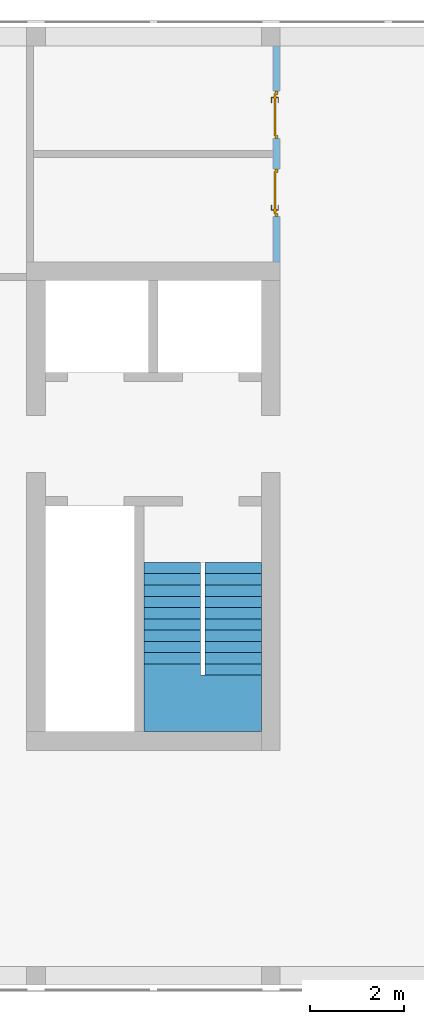
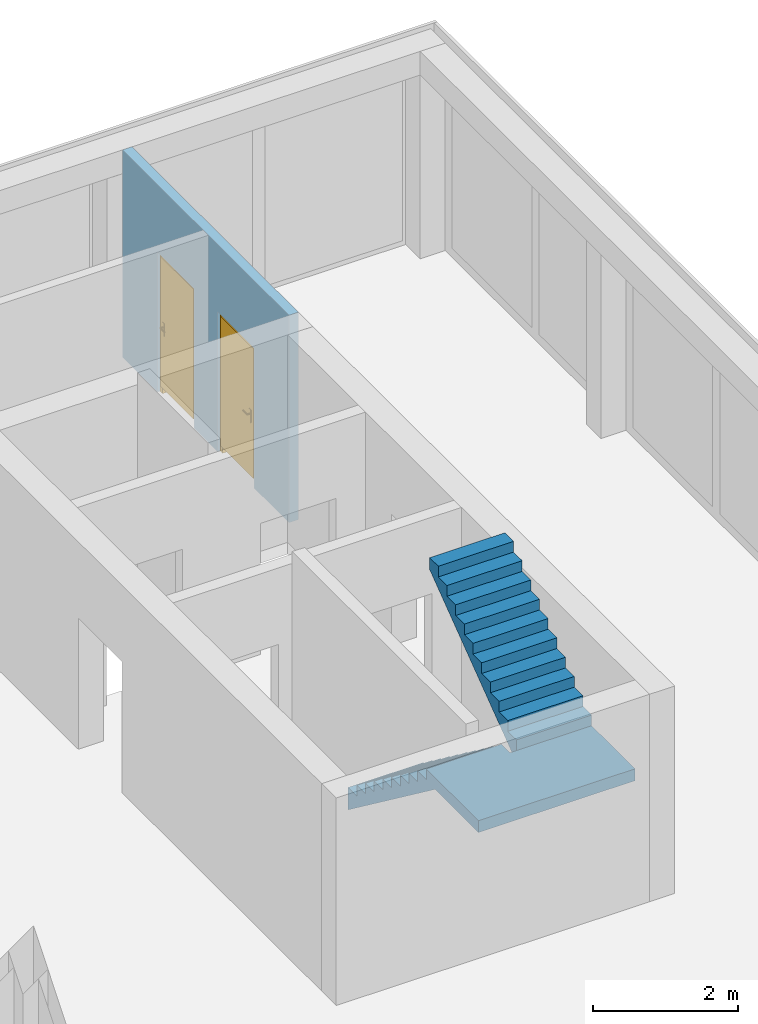
# One storey, part 4 of 6: 2 doors, 1 stair, 2 openings, plus 1 element that does not belong to this part.
"""IFC2X3 building model written with IfcOpenShell, lengths in metres."""

from ifc_helpers import new_model, entity, si_unit, converted_unit, frame, frame_2d, origin, origin_with_axes, place, context, subcontext, project, spatial, polyline, rectangle, outline, extrude, faceted_brep, source, transform, mapped, material, layer, layer_set, layer_usage, type_object, element, fill, save


model = new_model("IFC2X3")

# Units and contexts
model_context = context("Model", 3, precision=1e-05, world=origin())
body_context = subcontext(model_context, "Body", "Model", "MODEL_VIEW")
ifc_project = project(units=[si_unit("LENGTHUNIT", "METRE"), si_unit("AREAUNIT", "SQUARE_METRE"), si_unit("VOLUMEUNIT", "CUBIC_METRE"), si_unit("MASSUNIT", "GRAM", prefix="KILO"), converted_unit("PLANEANGLEUNIT", "DEGREE", entity("IfcPlaneAngleMeasure", 0.0174532925199433), si_unit("PLANEANGLEUNIT", "RADIAN"), dimensions=[0, 0, 0, 0, 0, 0, 0])], contexts=[model_context])

# Site, building, storey
site_placement = place(None, origin())
site = spatial("IfcSite", under=ifc_project, at=site_placement, CompositionType="ELEMENT")
building_placement = place(site_placement, origin())
building = spatial("IfcBuilding", under=site, at=building_placement, CompositionType="ELEMENT")
storey_placement = place(building_placement, frame((0.0, 0.0, 8.6)))
storey = spatial("IfcBuildingStorey", under=building, at=storey_placement, Name="2. Obergeschoss", CompositionType="ELEMENT", Elevation=8.6)

# Wall, openings, doors
ifc_material_1 = material()
ifc_layer = layer(ifc_material_1, 0.15)
ifc_layer_set = layer_set([ifc_layer])
ifc_layer_usage = layer_usage(ifc_layer_set, "AXIS2", "POSITIVE", -0.15)
wall_placement = place(storey_placement, frame((25.25, 20.0, 0.0), z_axis=(0.0, 0.0, 1.0), x_axis=(0.0, -1.0, 0.0)))
wall = element("IfcWallStandardCase", 1, at=wall_placement, inside=storey, material=ifc_layer_usage, context=body_context, shape_type="SweptSolid", body=[
    extrude(rectangle(XDim=4.6, YDim=0.15, at=frame_2d((2.3, 0.075), x_axis=(1.0, 0.0))), origin_with_axes(), (0.0, 0.0, 1.0), 3.5),
])
opening_1_placement = place(wall_placement, frame((3.635, 0.15, 0.0), z_axis=(0.0, -1.0, 0.0), x_axis=(0.0, 0.0, 1.0)))
opening_1 = element("IfcOpeningElement", 2, at=opening_1_placement, cuts=wall, ObjectType="Opening", context=body_context, shape_type="SweptSolid", body=[
    extrude(outline(polyline([(0.0, 1.01), (2.36, 1.01), (2.36, 0.0), (0.0, 0.0), (0.0, 1.01)])), origin_with_axes(), (0.0, 0.0, 1.0), 0.15),
])
opening_2_placement = place(wall_placement, frame((1.975, 0.15, 0.0), z_axis=(0.0, -1.0, 0.0), x_axis=(0.0, 0.0, 1.0)))
opening_2 = element("IfcOpeningElement", 3, at=opening_2_placement, cuts=wall, ObjectType="Opening", context=body_context, shape_type="SweptSolid", body=[
    extrude(outline(polyline([(0.0, 1.01), (2.36, 1.01), (2.36, 0.0), (0.0, 0.0), (0.0, 1.01)])), origin_with_axes(), (0.0, 0.0, 1.0), 0.15),
])
ifc_material_2 = material()
door_style_1 = type_object("IfcDoorStyle", ConstructionType="NOTDEFINED", OperationType="SINGLE_SWING_RIGHT", ParameterTakesPrecedence=False, Sizeable=False)
shared_shape_1 = source(origin_with_axes(), body_context, "Body", "Brep", [
    faceted_brep([(0.0, 0.07, 2.36), (0.0, 0.07, 0.0), (0.07, 0.07, 0.0), (0.07, 0.07, 2.36), (0.0, 0.0, 0.0), (0.0, 0.0, 2.36), (0.07, 0.0, 2.36), (0.07, 0.0, 0.0)], [[[0, 1, 2, 3]], [[4, 5, 6, 7]], [[1, 0, 5, 4]], [[2, 1, 4, 7]], [[3, 2, 7, 6]], [[0, 3, 6, 5]]], orient=[[False], [False], [False], [False], [False], [False]]),
    faceted_brep([(0.94, 0.07, 2.36), (0.94, 0.07, 0.0), (1.01, 0.07, 0.0), (1.01, 0.07, 2.36), (0.94, 0.0, 0.0), (0.94, 0.0, 2.36), (1.01, 0.0, 2.36), (1.01, 0.0, 0.0)], [[[0, 1, 2, 3]], [[4, 5, 6, 7]], [[1, 0, 5, 4]], [[2, 1, 4, 7]], [[3, 2, 7, 6]], [[0, 3, 6, 5]]], orient=[[False], [False], [False], [False], [False], [False]]),
    faceted_brep([(0.07, 0.07, 2.36), (0.07, 0.07, 2.29), (0.94, 0.07, 2.29), (0.94, 0.07, 2.36), (0.07, 0.0, 2.29), (0.07, 0.0, 2.36), (0.94, 0.0, 2.36), (0.94, 0.0, 2.29)], [[[0, 1, 2, 3]], [[4, 5, 6, 7]], [[1, 0, 5, 4]], [[2, 1, 4, 7]], [[3, 2, 7, 6]], [[0, 3, 6, 5]]], orient=[[False], [False], [False], [False], [False], [False]]),
    faceted_brep([(0.05, 0.09, 2.31), (0.05, 0.09, 0.121), (0.96, 0.09, 0.121), (0.96, 0.09, 2.31), (0.05, 0.05, 0.121), (0.05, 0.05, 2.31), (0.96, 0.05, 2.31), (0.96, 0.05, 0.121)], [[[0, 1, 2, 3]], [[4, 5, 6, 7]], [[1, 0, 5, 4]], [[2, 1, 4, 7]], [[3, 2, 7, 6]], [[0, 3, 6, 5]]], orient=[[False], [False], [False], [False], [False], [False]]),
    faceted_brep([(0.11, 0.05, 1.246), (0.11, 0.05, 1.031), (0.16, 0.05, 1.031), (0.16, 0.05, 1.246), (0.11, 0.04, 1.031), (0.11, 0.04, 1.246), (0.16, 0.04, 1.246), (0.16, 0.04, 1.031)], [[[0, 1, 2, 3]], [[4, 5, 6, 7]], [[1, 0, 5, 4]], [[2, 1, 4, 7]], [[3, 2, 7, 6]], [[0, 3, 6, 5]]], orient=[[False], [False], [False], [False], [False], [False]]),
    faceted_brep([(0.135, 0.04, 1.181), (0.13, 0.04, 1.17966025403784), (0.126339745962156, 0.04, 1.176), (0.125, 0.04, 1.171), (0.126339745962156, 0.04, 1.166), (0.13, 0.04, 1.16233974596216), (0.135, 0.04, 1.161), (0.14, 0.04, 1.16233974596216), (0.143660254037844, 0.04, 1.166), (0.145, 0.04, 1.171), (0.143660254037844, 0.04, 1.176), (0.14, 0.04, 1.17966025403784), (0.135, 0.0, 1.181), (0.13, -0.005, 1.17966025403784), (0.126339745962156, -0.00866025403784442, 1.176), (0.125, -0.01, 1.171), (0.126339745962156, -0.00866025403784442, 1.166), (0.13, -0.005, 1.16233974596216), (0.135, 0.0, 1.161), (0.14, 0.005, 1.16233974596216), (0.143660254037844, 0.00866025403784442, 1.166), (0.145, 0.01, 1.171), (0.143660254037844, 0.00866025403784442, 1.176), (0.14, 0.005, 1.17966025403784), (0.25, 0.0, 1.181), (0.25, 0.005, 1.17966025403784), (0.25, 0.00866025403784442, 1.176), (0.25, 0.01, 1.171), (0.25, 0.00866025403784442, 1.166), (0.25, 0.005, 1.16233974596216), (0.25, 0.0, 1.161), (0.25, -0.005, 1.16233974596216), (0.25, -0.00866025403784442, 1.166), (0.25, -0.01, 1.171), (0.25, -0.00866025403784442, 1.176), (0.25, -0.005, 1.17966025403784)], [[[0, 1, 2, 3, 4, 5, 6, 7, 8, 9, 10, 11]], [[0, 12, 13, 1]], [[1, 13, 14, 2]], [[2, 14, 15, 3]], [[3, 15, 16, 4]], [[4, 16, 17, 5]], [[5, 17, 18, 6]], [[6, 18, 19, 7]], [[7, 19, 20, 8]], [[8, 20, 21, 9]], [[9, 21, 22, 10]], [[10, 22, 23, 11]], [[11, 23, 12, 0]], [[24, 25, 26, 27, 28, 29, 30, 31, 32, 33, 34, 35]], [[12, 24, 35, 13]], [[13, 35, 34, 14]], [[14, 34, 33, 15]], [[15, 33, 32, 16]], [[16, 32, 31, 17]], [[17, 31, 30, 18]], [[18, 30, 29, 19]], [[19, 29, 28, 20]], [[20, 28, 27, 21]], [[21, 27, 26, 22]], [[22, 26, 25, 23]], [[23, 25, 24, 12]]], orient=[[False], [False], [False], [False], [False], [False], [False], [False], [False], [False], [False], [False], [False], [False], [False], [False], [False], [False], [False], [False], [False], [False], [False], [False], [False], [False]]),
    faceted_brep([(0.11, 0.09, 1.246), (0.16, 0.09, 1.246), (0.16, 0.09, 1.031), (0.11, 0.09, 1.031), (0.11, 0.1, 1.031), (0.16, 0.1, 1.031), (0.16, 0.1, 1.246), (0.11, 0.1, 1.246)], [[[0, 1, 2, 3]], [[4, 5, 6, 7]], [[3, 4, 7, 0]], [[2, 5, 4, 3]], [[1, 6, 5, 2]], [[0, 7, 6, 1]]], orient=[[False], [False], [False], [False], [False], [False]]),
    faceted_brep([(0.135, 0.1, 1.181), (0.14, 0.1, 1.17966025403784), (0.143660254037844, 0.1, 1.176), (0.145, 0.1, 1.171), (0.143660254037844, 0.1, 1.166), (0.14, 0.1, 1.16233974596216), (0.135, 0.1, 1.161), (0.13, 0.1, 1.16233974596216), (0.126339745962156, 0.1, 1.166), (0.125, 0.1, 1.171), (0.126339745962156, 0.1, 1.176), (0.13, 0.1, 1.17966025403784), (0.13, 0.145, 1.17966025403784), (0.135, 0.14, 1.181), (0.126339745962156, 0.148660254037844, 1.176), (0.125, 0.15, 1.171), (0.126339745962156, 0.148660254037844, 1.166), (0.13, 0.145, 1.16233974596216), (0.135, 0.14, 1.161), (0.14, 0.135, 1.16233974596216), (0.143660254037844, 0.131339745962156, 1.166), (0.145, 0.13, 1.171), (0.143660254037844, 0.131339745962156, 1.176), (0.14, 0.135, 1.17966025403784), (0.25, 0.14, 1.181), (0.25, 0.145, 1.17966025403784), (0.25, 0.148660254037844, 1.176), (0.25, 0.15, 1.171), (0.25, 0.148660254037844, 1.166), (0.25, 0.145, 1.16233974596216), (0.25, 0.14, 1.161), (0.25, 0.135, 1.16233974596216), (0.25, 0.131339745962156, 1.166), (0.25, 0.13, 1.171), (0.25, 0.131339745962156, 1.176), (0.25, 0.135, 1.17966025403784)], [[[0, 1, 2, 3, 4, 5, 6, 7, 8, 9, 10, 11]], [[0, 11, 12, 13]], [[11, 10, 14, 12]], [[10, 9, 15, 14]], [[9, 8, 16, 15]], [[8, 7, 17, 16]], [[7, 6, 18, 17]], [[6, 5, 19, 18]], [[5, 4, 20, 19]], [[4, 3, 21, 20]], [[3, 2, 22, 21]], [[2, 1, 23, 22]], [[1, 0, 13, 23]], [[24, 25, 26, 27, 28, 29, 30, 31, 32, 33, 34, 35]], [[13, 12, 25, 24]], [[12, 14, 26, 25]], [[14, 15, 27, 26]], [[15, 16, 28, 27]], [[16, 17, 29, 28]], [[17, 18, 30, 29]], [[18, 19, 31, 30]], [[19, 20, 32, 31]], [[20, 21, 33, 32]], [[21, 22, 34, 33]], [[22, 23, 35, 34]], [[23, 13, 24, 35]]], orient=[[False], [False], [False], [False], [False], [False], [False], [False], [False], [False], [False], [False], [False], [False], [False], [False], [False], [False], [False], [False], [False], [False], [False], [False], [False], [False]]),
])
door_1_placement = place(opening_1_placement, frame((0.0, 0.0, 0.04), z_axis=(1.0, 0.0, 0.0), x_axis=(0.0, 1.0, 0.0)))
door_1 = element("IfcDoor", 4, at=door_1_placement, inside=storey, type_object=door_style_1, material=ifc_material_2, OverallHeight=2.36, OverallWidth=1.01, context=body_context, shape_type="MappedRepresentation", body=[
    mapped(shared_shape_1, transform((0.0, 0.0, 0.0), x_axis=(1.0, 0.0, 0.0), y_axis=(0.0, 1.0, 0.0), z_axis=(0.0, 0.0, 1.0), scale=1.0)),
])
fill(opening_1, door_1)
ifc_material_3 = material()
door_style_2 = type_object("IfcDoorStyle", ConstructionType="NOTDEFINED", OperationType="SINGLE_SWING_RIGHT", ParameterTakesPrecedence=False, Sizeable=False)
shared_shape_2 = source(origin_with_axes(), body_context, "Body", "Brep", [
    faceted_brep([(1.01, 0.07, 2.36), (0.94, 0.07, 2.36), (0.94, 0.07, 0.0), (1.01, 0.07, 0.0), (1.01, 0.0, 0.0), (0.94, 0.0, 0.0), (0.94, 0.0, 2.36), (1.01, 0.0, 2.36)], [[[0, 1, 2, 3]], [[4, 5, 6, 7]], [[3, 4, 7, 0]], [[2, 5, 4, 3]], [[1, 6, 5, 2]], [[0, 7, 6, 1]]], orient=[[False], [False], [False], [False], [False], [False]]),
    faceted_brep([(0.07, 0.07, 2.36), (0.0, 0.07, 2.36), (0.0, 0.07, 0.0), (0.07, 0.07, 0.0), (0.07, 0.0, 0.0), (0.0, 0.0, 0.0), (0.0, 0.0, 2.36), (0.07, 0.0, 2.36)], [[[0, 1, 2, 3]], [[4, 5, 6, 7]], [[3, 4, 7, 0]], [[2, 5, 4, 3]], [[1, 6, 5, 2]], [[0, 7, 6, 1]]], orient=[[False], [False], [False], [False], [False], [False]]),
    faceted_brep([(0.94, 0.07, 2.36), (0.07, 0.07, 2.36), (0.07, 0.07, 2.29), (0.94, 0.07, 2.29), (0.94, 0.0, 2.29), (0.07, 0.0, 2.29), (0.07, 0.0, 2.36), (0.94, 0.0, 2.36)], [[[0, 1, 2, 3]], [[4, 5, 6, 7]], [[3, 4, 7, 0]], [[2, 5, 4, 3]], [[1, 6, 5, 2]], [[0, 7, 6, 1]]], orient=[[False], [False], [False], [False], [False], [False]]),
    faceted_brep([(0.96, 0.09, 2.31), (0.05, 0.09, 2.31), (0.05, 0.09, 0.121), (0.96, 0.09, 0.121), (0.96, 0.05, 0.121), (0.05, 0.05, 0.121), (0.05, 0.05, 2.31), (0.96, 0.05, 2.31)], [[[0, 1, 2, 3]], [[4, 5, 6, 7]], [[3, 4, 7, 0]], [[2, 5, 4, 3]], [[1, 6, 5, 2]], [[0, 7, 6, 1]]], orient=[[False], [False], [False], [False], [False], [False]]),
    faceted_brep([(0.9, 0.05, 1.246), (0.85, 0.05, 1.246), (0.85, 0.05, 1.031), (0.9, 0.05, 1.031), (0.9, 0.04, 1.031), (0.85, 0.04, 1.031), (0.85, 0.04, 1.246), (0.9, 0.04, 1.246)], [[[0, 1, 2, 3]], [[4, 5, 6, 7]], [[3, 4, 7, 0]], [[2, 5, 4, 3]], [[1, 6, 5, 2]], [[0, 7, 6, 1]]], orient=[[False], [False], [False], [False], [False], [False]]),
    faceted_brep([(0.875, 0.04, 1.181), (0.87, 0.04, 1.17966025403784), (0.866339745962156, 0.04, 1.176), (0.865, 0.04, 1.171), (0.866339745962156, 0.04, 1.166), (0.87, 0.04, 1.16233974596216), (0.875, 0.04, 1.161), (0.88, 0.04, 1.16233974596216), (0.883660254037844, 0.04, 1.166), (0.885, 0.04, 1.171), (0.883660254037844, 0.04, 1.176), (0.88, 0.04, 1.17966025403784), (0.88, -0.005, 1.17966025403784), (0.875, 0.0, 1.181), (0.883660254037844, -0.00866025403784442, 1.176), (0.885, -0.01, 1.171), (0.883660254037844, -0.00866025403784442, 1.166), (0.88, -0.005, 1.16233974596216), (0.875, 0.0, 1.161), (0.87, 0.005, 1.16233974596216), (0.866339745962156, 0.00866025403784442, 1.166), (0.865, 0.01, 1.171), (0.866339745962156, 0.00866025403784442, 1.176), (0.87, 0.005, 1.17966025403784), (0.76, 0.0, 1.181), (0.76, -0.005, 1.17966025403784), (0.76, -0.00866025403784442, 1.176), (0.76, -0.01, 1.171), (0.76, -0.00866025403784442, 1.166), (0.76, -0.005, 1.16233974596216), (0.76, 0.0, 1.161), (0.76, 0.005, 1.16233974596216), (0.76, 0.00866025403784442, 1.166), (0.76, 0.01, 1.171), (0.76, 0.00866025403784442, 1.176), (0.76, 0.005, 1.17966025403784)], [[[0, 1, 2, 3, 4, 5, 6, 7, 8, 9, 10, 11]], [[0, 11, 12, 13]], [[11, 10, 14, 12]], [[10, 9, 15, 14]], [[9, 8, 16, 15]], [[8, 7, 17, 16]], [[7, 6, 18, 17]], [[6, 5, 19, 18]], [[5, 4, 20, 19]], [[4, 3, 21, 20]], [[3, 2, 22, 21]], [[2, 1, 23, 22]], [[1, 0, 13, 23]], [[24, 25, 26, 27, 28, 29, 30, 31, 32, 33, 34, 35]], [[13, 12, 25, 24]], [[12, 14, 26, 25]], [[14, 15, 27, 26]], [[15, 16, 28, 27]], [[16, 17, 29, 28]], [[17, 18, 30, 29]], [[18, 19, 31, 30]], [[19, 20, 32, 31]], [[20, 21, 33, 32]], [[21, 22, 34, 33]], [[22, 23, 35, 34]], [[23, 13, 24, 35]]], orient=[[False], [False], [False], [False], [False], [False], [False], [False], [False], [False], [False], [False], [False], [False], [False], [False], [False], [False], [False], [False], [False], [False], [False], [False], [False], [False]]),
    faceted_brep([(0.9, 0.09, 1.246), (0.9, 0.09, 1.031), (0.85, 0.09, 1.031), (0.85, 0.09, 1.246), (0.9, 0.1, 1.031), (0.9, 0.1, 1.246), (0.85, 0.1, 1.246), (0.85, 0.1, 1.031)], [[[0, 1, 2, 3]], [[4, 5, 6, 7]], [[1, 0, 5, 4]], [[2, 1, 4, 7]], [[3, 2, 7, 6]], [[0, 3, 6, 5]]], orient=[[False], [False], [False], [False], [False], [False]]),
    faceted_brep([(0.875, 0.1, 1.181), (0.88, 0.1, 1.17966025403784), (0.883660254037844, 0.1, 1.176), (0.885, 0.1, 1.171), (0.883660254037844, 0.1, 1.166), (0.88, 0.1, 1.16233974596216), (0.875, 0.1, 1.161), (0.87, 0.1, 1.16233974596216), (0.866339745962156, 0.1, 1.166), (0.865, 0.1, 1.171), (0.866339745962156, 0.1, 1.176), (0.87, 0.1, 1.17966025403784), (0.875, 0.14, 1.181), (0.88, 0.145, 1.17966025403784), (0.883660254037844, 0.148660254037844, 1.176), (0.885, 0.15, 1.171), (0.883660254037844, 0.148660254037844, 1.166), (0.88, 0.145, 1.16233974596216), (0.875, 0.14, 1.161), (0.87, 0.135, 1.16233974596216), (0.866339745962156, 0.131339745962156, 1.166), (0.865, 0.13, 1.171), (0.866339745962156, 0.131339745962156, 1.176), (0.87, 0.135, 1.17966025403784), (0.76, 0.14, 1.181), (0.76, 0.135, 1.17966025403784), (0.76, 0.131339745962156, 1.176), (0.76, 0.13, 1.171), (0.76, 0.131339745962156, 1.166), (0.76, 0.135, 1.16233974596216), (0.76, 0.14, 1.161), (0.76, 0.145, 1.16233974596216), (0.76, 0.148660254037844, 1.166), (0.76, 0.15, 1.171), (0.76, 0.148660254037844, 1.176), (0.76, 0.145, 1.17966025403784)], [[[0, 1, 2, 3, 4, 5, 6, 7, 8, 9, 10, 11]], [[0, 12, 13, 1]], [[1, 13, 14, 2]], [[2, 14, 15, 3]], [[3, 15, 16, 4]], [[4, 16, 17, 5]], [[5, 17, 18, 6]], [[6, 18, 19, 7]], [[7, 19, 20, 8]], [[8, 20, 21, 9]], [[9, 21, 22, 10]], [[10, 22, 23, 11]], [[11, 23, 12, 0]], [[24, 25, 26, 27, 28, 29, 30, 31, 32, 33, 34, 35]], [[12, 24, 35, 13]], [[13, 35, 34, 14]], [[14, 34, 33, 15]], [[15, 33, 32, 16]], [[16, 32, 31, 17]], [[17, 31, 30, 18]], [[18, 30, 29, 19]], [[19, 29, 28, 20]], [[20, 28, 27, 21]], [[21, 27, 26, 22]], [[22, 26, 25, 23]], [[23, 25, 24, 12]]], orient=[[False], [False], [False], [False], [False], [False], [False], [False], [False], [False], [False], [False], [False], [False], [False], [False], [False], [False], [False], [False], [False], [False], [False], [False], [False], [False]]),
])
door_2_placement = place(opening_2_placement, frame((0.0, 0.0, 0.04), z_axis=(1.0, 0.0, 0.0), x_axis=(0.0, 1.0, 0.0)))
door_2 = element("IfcDoor", 5, at=door_2_placement, inside=storey, type_object=door_style_2, material=ifc_material_3, OverallHeight=2.36, OverallWidth=1.01, context=body_context, shape_type="MappedRepresentation", body=[
    mapped(shared_shape_2, transform((0.0, 0.0, 0.0), x_axis=(1.0, 0.0, 0.0), y_axis=(0.0, 1.0, 0.0), z_axis=(0.0, 0.0, 1.0), scale=1.0)),
])
fill(opening_2, door_2)

# Stair
ifc_material_4 = material(Name="FT_STB C45")
stair_placement = place(storey_placement, frame((22.5, 5.4, 0.0)))
element("IfcStair", 6, at=stair_placement, inside=storey, material=ifc_material_4, Name="II", ShapeType="NOTDEFINED", context=body_context, shape_type="Brep", body=[
    faceted_brep([(1.201, 1.2, 1.8), (1.201, 0.0, 1.8), (2.5, 0.0, 1.8), (2.5, 1.2001, 1.8), (1.3, 1.2001, 1.8), (1.3, 1.2, 1.8), (1.201, 0.0, 2.0), (1.201, 1.2, 2.0), (1.3, 1.2, 2.0), (1.3, 1.2001, 2.0), (2.5, 1.2001, 2.0), (2.5, 0.0, 2.0)], [[[0, 1, 2, 3, 4, 5]], [[6, 7, 8, 9, 10, 11]], [[1, 0, 7, 6]], [[2, 1, 6, 11]], [[3, 2, 11, 10]], [[4, 3, 10, 9]], [[5, 4, 9, 8]], [[0, 5, 8, 7]]], orient=[[False], [False], [False], [False], [False], [False], [False], [False]]),
    faceted_brep([(2.5, 3.12002, 3.24), (2.5, 3.36001, 3.42), (1.3, 3.36001, 3.42), (1.3, 3.12002, 3.24), (1.3, 3.12002, 3.62), (1.3, 3.36001, 3.62), (2.5, 3.36001, 3.62), (2.5, 3.12002, 3.62)], [[[0, 1, 2, 3]], [[4, 5, 6, 7]], [[3, 4, 7, 0]], [[0, 7, 6, 1]], [[1, 6, 5, 2]], [[2, 5, 4, 3]]], orient=[[False], [False], [False], [False], [False], [False]]),
    faceted_brep([(2.5, 2.88003, 3.06), (2.5, 3.12002, 3.24), (1.3, 3.12002, 3.24), (1.3, 2.88003, 3.06), (1.3, 2.88003, 3.44), (1.3, 3.12002, 3.44), (2.5, 3.12002, 3.44), (2.5, 2.88003, 3.44)], [[[0, 1, 2, 3]], [[4, 5, 6, 7]], [[3, 4, 7, 0]], [[0, 7, 6, 1]], [[1, 6, 5, 2]], [[2, 5, 4, 3]]], orient=[[False], [False], [False], [False], [False], [False]]),
    faceted_brep([(2.5, 2.64004, 2.88), (2.5, 2.88003, 3.06), (1.3, 2.88003, 3.06), (1.3, 2.64004, 2.88), (1.3, 2.64004, 3.26), (1.3, 2.88003, 3.26), (2.5, 2.88003, 3.26), (2.5, 2.64004, 3.26)], [[[0, 1, 2, 3]], [[4, 5, 6, 7]], [[3, 4, 7, 0]], [[0, 7, 6, 1]], [[1, 6, 5, 2]], [[2, 5, 4, 3]]], orient=[[False], [False], [False], [False], [False], [False]]),
    faceted_brep([(2.5, 2.40005, 2.7), (2.5, 2.64004, 2.88), (1.3, 2.64004, 2.88), (1.3, 2.40005, 2.7), (1.3, 2.40005, 3.08), (1.3, 2.64004, 3.08), (2.5, 2.64004, 3.08), (2.5, 2.40005, 3.08)], [[[0, 1, 2, 3]], [[4, 5, 6, 7]], [[3, 4, 7, 0]], [[0, 7, 6, 1]], [[1, 6, 5, 2]], [[2, 5, 4, 3]]], orient=[[False], [False], [False], [False], [False], [False]]),
    faceted_brep([(2.5, 2.16006, 2.52), (2.5, 2.40005, 2.7), (1.3, 2.40005, 2.7), (1.3, 2.16006, 2.52), (1.3, 2.16006, 2.9), (1.3, 2.40005, 2.9), (2.5, 2.40005, 2.9), (2.5, 2.16006, 2.9)], [[[0, 1, 2, 3]], [[4, 5, 6, 7]], [[3, 4, 7, 0]], [[0, 7, 6, 1]], [[1, 6, 5, 2]], [[2, 5, 4, 3]]], orient=[[False], [False], [False], [False], [False], [False]]),
    faceted_brep([(2.5, 1.92007, 2.34), (2.5, 2.16006, 2.52), (1.3, 2.16006, 2.52), (1.3, 1.92007, 2.34), (1.3, 1.92007, 2.72), (1.3, 2.16006, 2.72), (2.5, 2.16006, 2.72), (2.5, 1.92007, 2.72)], [[[0, 1, 2, 3]], [[4, 5, 6, 7]], [[3, 4, 7, 0]], [[0, 7, 6, 1]], [[1, 6, 5, 2]], [[2, 5, 4, 3]]], orient=[[False], [False], [False], [False], [False], [False]]),
    faceted_brep([(2.5, 1.68008, 2.16), (2.5, 1.92007, 2.34), (1.3, 1.92007, 2.34), (1.3, 1.68008, 2.16), (1.3, 1.68008, 2.54), (1.3, 1.92007, 2.54), (2.5, 1.92007, 2.54), (2.5, 1.68008, 2.54)], [[[0, 1, 2, 3]], [[4, 5, 6, 7]], [[3, 4, 7, 0]], [[0, 7, 6, 1]], [[1, 6, 5, 2]], [[2, 5, 4, 3]]], orient=[[False], [False], [False], [False], [False], [False]]),
    faceted_brep([(2.5, 1.44009, 1.98), (2.5, 1.68008, 2.16), (1.3, 1.68008, 2.16), (1.3, 1.44009, 1.98), (1.3, 1.44009, 2.36), (1.3, 1.68008, 2.36), (2.5, 1.68008, 2.36), (2.5, 1.44009, 2.36)], [[[0, 1, 2, 3]], [[4, 5, 6, 7]], [[3, 4, 7, 0]], [[0, 7, 6, 1]], [[1, 6, 5, 2]], [[2, 5, 4, 3]]], orient=[[False], [False], [False], [False], [False], [False]]),
    faceted_brep([(2.5, 1.2001, 1.8), (2.5, 1.44009, 1.98), (1.3, 1.44009, 1.98), (1.3, 1.2001, 1.8), (1.3, 1.2001, 2.18), (1.3, 1.44009, 2.18), (2.5, 1.44009, 2.18), (2.5, 1.2001, 2.18)], [[[0, 1, 2, 3]], [[4, 5, 6, 7]], [[3, 4, 7, 0]], [[0, 7, 6, 1]], [[1, 6, 5, 2]], [[2, 5, 4, 3]]], orient=[[False], [False], [False], [False], [False], [False]]),
    faceted_brep([(1.2, 1.2001, 1.8), (0.0, 1.2001, 1.8), (0.0, 0.0, 1.8), (1.201, 0.0, 1.8), (1.201, 1.2, 1.8), (1.2, 1.2, 1.8), (0.0, 1.2001, 2.0), (1.2, 1.2001, 2.0), (1.2, 1.2, 2.0), (1.201, 1.2, 2.0), (1.201, 0.0, 2.0), (0.0, 0.0, 2.0)], [[[0, 1, 2, 3, 4, 5]], [[6, 7, 8, 9, 10, 11]], [[1, 0, 7, 6]], [[2, 1, 6, 11]], [[3, 2, 11, 10]], [[4, 3, 10, 9]], [[5, 4, 9, 8]], [[0, 5, 8, 7]]], orient=[[False], [False], [False], [False], [False], [False], [False], [False]]),
    faceted_brep([(0.0, 1.44009, 1.62), (0.0, 1.2001, 1.8), (1.2, 1.2001, 1.8), (1.2, 1.44009, 1.62), (1.2, 1.44009, 2.0), (1.2, 1.2001, 2.0), (0.0, 1.2001, 2.0), (0.0, 1.44009, 2.0)], [[[0, 1, 2, 3]], [[4, 5, 6, 7]], [[3, 4, 7, 0]], [[0, 7, 6, 1]], [[1, 6, 5, 2]], [[2, 5, 4, 3]]], orient=[[False], [False], [False], [False], [False], [False]]),
    faceted_brep([(0.0, 1.68008, 1.44), (0.0, 1.44009, 1.62), (1.2, 1.44009, 1.62), (1.2, 1.68008, 1.44), (1.2, 1.68008, 1.82), (1.2, 1.44009, 1.82), (0.0, 1.44009, 1.82), (0.0, 1.68008, 1.82)], [[[0, 1, 2, 3]], [[4, 5, 6, 7]], [[3, 4, 7, 0]], [[0, 7, 6, 1]], [[1, 6, 5, 2]], [[2, 5, 4, 3]]], orient=[[False], [False], [False], [False], [False], [False]]),
    faceted_brep([(0.0, 1.92007, 1.26), (0.0, 1.68008, 1.44), (1.2, 1.68008, 1.44), (1.2, 1.92007, 1.26), (1.2, 1.92007, 1.64), (1.2, 1.68008, 1.64), (0.0, 1.68008, 1.64), (0.0, 1.92007, 1.64)], [[[0, 1, 2, 3]], [[4, 5, 6, 7]], [[3, 4, 7, 0]], [[0, 7, 6, 1]], [[1, 6, 5, 2]], [[2, 5, 4, 3]]], orient=[[False], [False], [False], [False], [False], [False]]),
    faceted_brep([(0.0, 2.16006, 1.08), (0.0, 1.92007, 1.26), (1.2, 1.92007, 1.26), (1.2, 2.16006, 1.08), (1.2, 2.16006, 1.46), (1.2, 1.92007, 1.46), (0.0, 1.92007, 1.46), (0.0, 2.16006, 1.46)], [[[0, 1, 2, 3]], [[4, 5, 6, 7]], [[3, 4, 7, 0]], [[0, 7, 6, 1]], [[1, 6, 5, 2]], [[2, 5, 4, 3]]], orient=[[False], [False], [False], [False], [False], [False]]),
    faceted_brep([(0.0, 2.40005, 0.9), (0.0, 2.16006, 1.08), (1.2, 2.16006, 1.08), (1.2, 2.40005, 0.9), (1.2, 2.40005, 1.28), (1.2, 2.16006, 1.28), (0.0, 2.16006, 1.28), (0.0, 2.40005, 1.28)], [[[0, 1, 2, 3]], [[4, 5, 6, 7]], [[3, 4, 7, 0]], [[0, 7, 6, 1]], [[1, 6, 5, 2]], [[2, 5, 4, 3]]], orient=[[False], [False], [False], [False], [False], [False]]),
    faceted_brep([(0.0, 2.64004, 0.72), (0.0, 2.40005, 0.9), (1.2, 2.40005, 0.9), (1.2, 2.64004, 0.72), (1.2, 2.64004, 1.1), (1.2, 2.40005, 1.1), (0.0, 2.40005, 1.1), (0.0, 2.64004, 1.1)], [[[0, 1, 2, 3]], [[4, 5, 6, 7]], [[3, 4, 7, 0]], [[0, 7, 6, 1]], [[1, 6, 5, 2]], [[2, 5, 4, 3]]], orient=[[False], [False], [False], [False], [False], [False]]),
    faceted_brep([(0.0, 2.88003, 0.54), (0.0, 2.64004, 0.72), (1.2, 2.64004, 0.72), (1.2, 2.88003, 0.54), (1.2, 2.88003, 0.92), (1.2, 2.64004, 0.92), (0.0, 2.64004, 0.92), (0.0, 2.88003, 0.92)], [[[0, 1, 2, 3]], [[4, 5, 6, 7]], [[3, 4, 7, 0]], [[0, 7, 6, 1]], [[1, 6, 5, 2]], [[2, 5, 4, 3]]], orient=[[False], [False], [False], [False], [False], [False]]),
    faceted_brep([(0.0, 3.12002, 0.36), (0.0, 2.88003, 0.54), (1.2, 2.88003, 0.54), (1.2, 3.12002, 0.36), (1.2, 3.12002, 0.74), (1.2, 2.88003, 0.74), (0.0, 2.88003, 0.74), (0.0, 3.12002, 0.74)], [[[0, 1, 2, 3]], [[4, 5, 6, 7]], [[3, 4, 7, 0]], [[0, 7, 6, 1]], [[1, 6, 5, 2]], [[2, 5, 4, 3]]], orient=[[False], [False], [False], [False], [False], [False]]),
    faceted_brep([(0.0, 3.36001, 0.18), (0.0, 3.12002, 0.36), (1.2, 3.12002, 0.36), (1.2, 3.36001, 0.18), (1.2, 3.36001, 0.56), (1.2, 3.12002, 0.56), (0.0, 3.12002, 0.56), (0.0, 3.36001, 0.56)], [[[0, 1, 2, 3]], [[4, 5, 6, 7]], [[3, 4, 7, 0]], [[0, 7, 6, 1]], [[1, 6, 5, 2]], [[2, 5, 4, 3]]], orient=[[False], [False], [False], [False], [False], [False]]),
    faceted_brep([(0.0, 3.6, 0.0), (0.0, 3.36001, 0.18), (1.2, 3.36001, 0.18), (1.2, 3.6, 0.0), (1.2, 3.6, 0.38), (1.2, 3.36001, 0.38), (0.0, 3.36001, 0.38), (0.0, 3.6, 0.38)], [[[0, 1, 2, 3]], [[4, 5, 6, 7]], [[3, 4, 7, 0]], [[0, 7, 6, 1]], [[1, 6, 5, 2]], [[2, 5, 4, 3]]], orient=[[False], [False], [False], [False], [False], [False]]),
    faceted_brep([(2.5, 3.36001, 3.42), (2.5, 3.6, 3.6), (1.3, 3.6, 3.6), (1.3, 3.36001, 3.42), (1.3, 3.36001, 3.8), (1.3, 3.6, 3.8), (2.5, 3.6, 3.8), (2.5, 3.36001, 3.8)], [[[0, 1, 2, 3]], [[4, 5, 6, 7]], [[3, 4, 7, 0]], [[0, 7, 6, 1]], [[1, 6, 5, 2]], [[2, 5, 4, 3]]], orient=[[False], [False], [False], [False], [False], [False]]),
])

save(model, "model.ifc")
